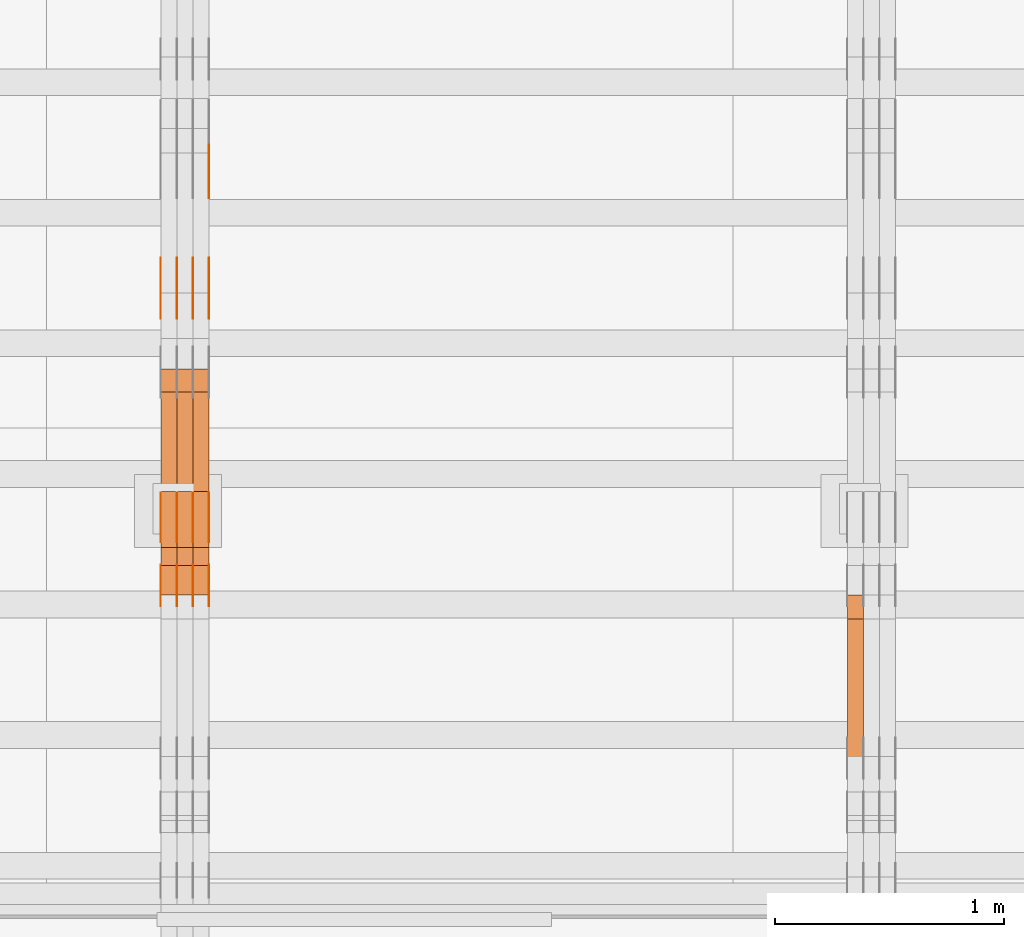
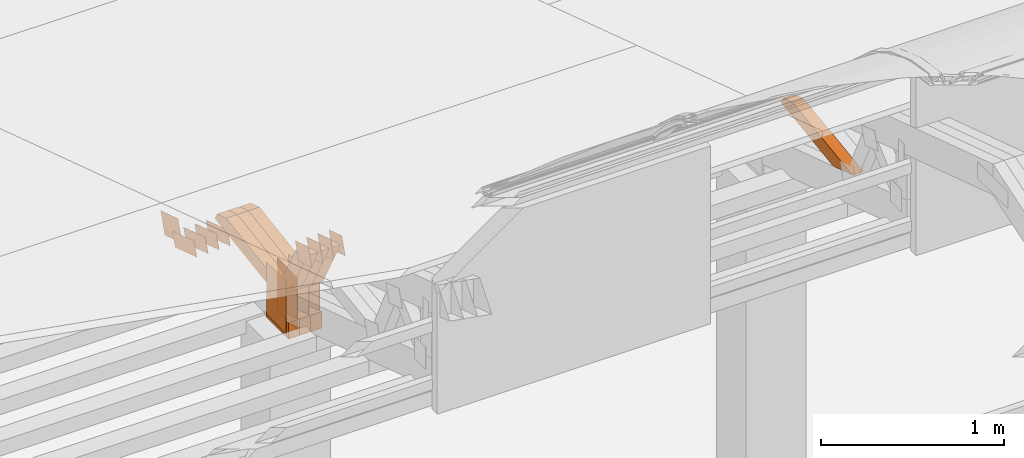
# One storey, part 291 of 385: 29 proxies.
"""IFC2X3 building model written with IfcOpenShell, lengths in millimetres."""

from ifc_helpers import new_model, entity, si_unit, converted_unit, derived_unit, direction, frame, origin, origin_2d_with_axis, place, context, subcontext, project, spatial, polyline, rectangle, outline, extrude, source, transform, mapped, material, type_object, type_shapes, element, save


model = new_model("IFC2X3")

# Units and contexts
model_context = context("Model", 3, precision=0.01, world=origin(), true_north=direction((6.12303176911189e-17, 1.0)))
body_context = subcontext(model_context, "Body", "Model", "MODEL_VIEW")
ifc_project = project(units=[si_unit("LENGTHUNIT", "METRE", prefix="MILLI"), si_unit("AREAUNIT", "SQUARE_METRE"), si_unit("VOLUMEUNIT", "CUBIC_METRE"), converted_unit("PLANEANGLEUNIT", "DEGREE", entity("IfcRatioMeasure", 0.0174532925199433), si_unit("PLANEANGLEUNIT", "RADIAN"), dimensions=[0, 0, 0, 0, 0, 0, 0]), si_unit("MASSUNIT", "GRAM", prefix="KILO"), derived_unit("MASSDENSITYUNIT", [(si_unit("MASSUNIT", "GRAM", prefix="KILO"), 1), (si_unit("LENGTHUNIT", "METRE"), -3)]), si_unit("TIMEUNIT", "SECOND"), si_unit("FREQUENCYUNIT", "HERTZ"), si_unit("THERMODYNAMICTEMPERATUREUNIT", "DEGREE_CELSIUS"), derived_unit("THERMALTRANSMITTANCEUNIT", [(si_unit("MASSUNIT", "GRAM", prefix="KILO"), 1), (si_unit("THERMODYNAMICTEMPERATUREUNIT", "KELVIN"), -1), (si_unit("TIMEUNIT", "SECOND"), -3)]), derived_unit("VOLUMETRICFLOWRATEUNIT", [(si_unit("LENGTHUNIT", "METRE"), 3), (si_unit("TIMEUNIT", "SECOND"), -1)]), si_unit("ELECTRICCURRENTUNIT", "AMPERE"), si_unit("ELECTRICVOLTAGEUNIT", "VOLT"), si_unit("POWERUNIT", "WATT"), si_unit("FORCEUNIT", "NEWTON", prefix="KILO"), si_unit("ILLUMINANCEUNIT", "LUX"), si_unit("LUMINOUSFLUXUNIT", "LUMEN"), si_unit("LUMINOUSINTENSITYUNIT", "CANDELA"), derived_unit("USERDEFINED", [(si_unit("MASSUNIT", "GRAM", prefix="KILO"), -1), (si_unit("LENGTHUNIT", "METRE"), -2), (si_unit("TIMEUNIT", "SECOND"), 3), (si_unit("LUMINOUSFLUXUNIT", "LUMEN"), 1)]), derived_unit("LINEARVELOCITYUNIT", [(si_unit("LENGTHUNIT", "METRE"), 1), (si_unit("TIMEUNIT", "SECOND"), -1)]), si_unit("PRESSUREUNIT", "PASCAL"), derived_unit("USERDEFINED", [(si_unit("LENGTHUNIT", "METRE"), -2), (si_unit("MASSUNIT", "GRAM", prefix="KILO"), 1), (si_unit("TIMEUNIT", "SECOND"), -2)])], contexts=[model_context])

# Site, building, storey
site_placement = place(None, origin())
site = spatial("IfcSite", under=ifc_project, at=site_placement, CompositionType="ELEMENT")
building_placement = place(site_placement, origin())
building = spatial("IfcBuilding", under=site, at=building_placement, CompositionType="ELEMENT")
storey_placement = place(building_placement, origin())
storey = spatial("IfcBuildingStorey", under=building, at=storey_placement, Name="Default", CompositionType="ELEMENT", Elevation=0.0)

# Proxies
ifc_material_1 = material(Name="IfcSurfaceStyle #464898")
building_element_proxy_type_1 = type_object("IfcBuildingElementProxyType", Name="T1-W8 464896", PredefinedType="NOTDEFINED", material=ifc_material_1)
shared_shape_1 = source(origin(), body_context, "Body", "SweptSolid", [
    extrude(outline(polyline([(-476.725263324644, -47.5001051695965), (180.672765845439, -47.5001051695965), (279.11020091716, -1.03605560390907e-06), (296.793624402619, 47.5001056876243), (-279.851327840575, 47.5001056876243), (-476.725263324644, -47.5001051695965)])), frame((296.793624402619, 47.5001056876243, 0.0), z_axis=(0.0, 0.0, 1.0), x_axis=(-1.0, 0.0, 0.0)), (0.0, 0.0, 1.0), 70.0),
])
type_shapes(building_element_proxy_type_1, [shared_shape_1])
proxy_1_placement = place(building_placement, frame((39245.0, 17036.40625, 3432.97192382813), z_axis=(-1.0, 0.0, 0.0), x_axis=(0.0, -0.990844046556832, -0.135011389900564)))
element("IfcBuildingElementProxy", 1, at=proxy_1_placement, inside=storey, type_object=building_element_proxy_type_1, material=ifc_material_1, Name="T1-W8", context=body_context, shape_type="MappedRepresentation", body=[
    mapped(shared_shape_1, transform((0.0, 0.0, 0.0), scale=1.0)),
])
ifc_material_2 = material(Name="IfcSurfaceStyle #445718")
building_element_proxy_type_2 = type_object("IfcBuildingElementProxyType", PredefinedType="NOTDEFINED", material=ifc_material_2)
shared_shape_2 = source(origin(), body_context, "Body", "SweptSolid", [
    extrude(outline(polyline([(-125.00031378339, -47.9999612158856), (125.000225258022, -47.9999612158856), (124.999811678525, 47.9999612158856), (-124.999723153156, 47.9999612158856), (-125.00031378339, -47.9999612158856)])), frame((125.000225258022, 48.0000091013474, 0.0), z_axis=(0.0, 0.0, 1.0), x_axis=(-1.0, 0.0, 0.0)), (0.0, 0.0, 1.0), 1.3),
])
type_shapes(building_element_proxy_type_2, [shared_shape_2])
proxy_2_placement = place(building_placement, frame((36386.3, 18456.8597683375, 2657.46691321253), z_axis=(-1.0, 0.0, 0.0), x_axis=(0.0, -0.951056516295124, 0.309016994375039)))
element("IfcBuildingElementProxy", 2, at=proxy_2_placement, inside=storey, type_object=building_element_proxy_type_2, material=ifc_material_2, context=body_context, shape_type="MappedRepresentation", body=[
    mapped(shared_shape_2, transform((0.0, 0.0, 0.0), scale=1.0)),
])
ifc_material_3 = material(Name="IfcSurfaceStyle #445661")
building_element_proxy_type_3 = type_object("IfcBuildingElementProxyType", PredefinedType="NOTDEFINED", material=ifc_material_3)
shared_shape_3 = source(origin(), body_context, "Body", "SweptSolid", [
    extrude(outline(polyline([(-125.00031378339, -47.9999612158856), (125.000225258022, -47.9999612158856), (124.999811678525, 47.9999612158856), (-124.999723153156, 47.9999612158856), (-125.00031378339, -47.9999612158856)])), frame((125.000225258022, 48.0000091013474, 0.0), z_axis=(0.0, 0.0, 1.0), x_axis=(-1.0, 0.0, 0.0)), (0.0, 0.0, 1.0), 1.3),
])
type_shapes(building_element_proxy_type_3, [shared_shape_3])
proxy_3_placement = place(building_placement, frame((36315.0, 18456.8597683375, 2657.46691321253), z_axis=(-1.0, 0.0, 0.0), x_axis=(0.0, -0.951056516295124, 0.309016994375039)))
element("IfcBuildingElementProxy", 3, at=proxy_3_placement, inside=storey, type_object=building_element_proxy_type_3, material=ifc_material_3, context=body_context, shape_type="MappedRepresentation", body=[
    mapped(shared_shape_3, transform((0.0, 0.0, 0.0), scale=1.0)),
])
ifc_material_4 = material(Name="IfcSurfaceStyle #445604")
building_element_proxy_type_4 = type_object("IfcBuildingElementProxyType", PredefinedType="NOTDEFINED", material=ifc_material_4)
shared_shape_4 = source(origin(), body_context, "Body", "SweptSolid", [
    extrude(outline(polyline([(-125.00031378339, -47.9999612158856), (125.000225258022, -47.9999612158856), (124.999811678525, 47.9999612158856), (-124.999723153156, 47.9999612158856), (-125.00031378339, -47.9999612158856)])), frame((125.000225258022, 48.0000091013474, 0.0), z_axis=(0.0, 0.0, 1.0), x_axis=(-1.0, 0.0, 0.0)), (0.0, 0.0, 1.0), 1.3),
])
type_shapes(building_element_proxy_type_4, [shared_shape_4])
proxy_4_placement = place(building_placement, frame((36316.3, 18456.8597683375, 2657.46691321253), z_axis=(-1.0, 0.0, 0.0), x_axis=(0.0, -0.951056516295124, 0.309016994375039)))
element("IfcBuildingElementProxy", 4, at=proxy_4_placement, inside=storey, type_object=building_element_proxy_type_4, material=ifc_material_4, context=body_context, shape_type="MappedRepresentation", body=[
    mapped(shared_shape_4, transform((0.0, 0.0, 0.0), scale=1.0)),
])
ifc_material_5 = material(Name="IfcSurfaceStyle #445547")
building_element_proxy_type_5 = type_object("IfcBuildingElementProxyType", PredefinedType="NOTDEFINED", material=ifc_material_5)
shared_shape_5 = source(origin(), body_context, "Body", "SweptSolid", [
    extrude(outline(polyline([(-125.00031378339, -47.9999612158856), (125.000225258022, -47.9999612158856), (124.999811678525, 47.9999612158856), (-124.999723153156, 47.9999612158856), (-125.00031378339, -47.9999612158856)])), frame((125.000225258022, 48.0000091013474, 0.0), z_axis=(0.0, 0.0, 1.0), x_axis=(-1.0, 0.0, 0.0)), (0.0, 0.0, 1.0), 1.29999999999998),
])
type_shapes(building_element_proxy_type_5, [shared_shape_5])
proxy_5_placement = place(building_placement, frame((36245.0, 18456.8597683375, 2657.46691321253), z_axis=(-1.0, 0.0, 0.0), x_axis=(0.0, -0.951056516295124, 0.309016994375039)))
element("IfcBuildingElementProxy", 5, at=proxy_5_placement, inside=storey, type_object=building_element_proxy_type_5, material=ifc_material_5, context=body_context, shape_type="MappedRepresentation", body=[
    mapped(shared_shape_5, transform((0.0, 0.0, 0.0), scale=1.0)),
])
ifc_material_6 = material(Name="IfcSurfaceStyle #445490")
building_element_proxy_type_6 = type_object("IfcBuildingElementProxyType", PredefinedType="NOTDEFINED", material=ifc_material_6)
shared_shape_6 = source(origin(), body_context, "Body", "SweptSolid", [
    extrude(outline(polyline([(-125.00031378339, -47.9999612158856), (125.000225258022, -47.9999612158856), (124.999811678525, 47.9999612158856), (-124.999723153156, 47.9999612158856), (-125.00031378339, -47.9999612158856)])), frame((125.000225258022, 48.0000091013474, 0.0), z_axis=(0.0, 0.0, 1.0), x_axis=(-1.0, 0.0, 0.0)), (0.0, 0.0, 1.0), 1.29999999999998),
])
type_shapes(building_element_proxy_type_6, [shared_shape_6])
proxy_6_placement = place(building_placement, frame((36246.3, 18456.8597683375, 2657.46691321253), z_axis=(-1.0, 0.0, 0.0), x_axis=(0.0, -0.951056516295124, 0.309016994375039)))
element("IfcBuildingElementProxy", 6, at=proxy_6_placement, inside=storey, type_object=building_element_proxy_type_6, material=ifc_material_6, context=body_context, shape_type="MappedRepresentation", body=[
    mapped(shared_shape_6, transform((0.0, 0.0, 0.0), scale=1.0)),
])
ifc_material_7 = material(Name="IfcSurfaceStyle #445433")
building_element_proxy_type_7 = type_object("IfcBuildingElementProxyType", PredefinedType="NOTDEFINED", material=ifc_material_7)
shared_shape_7 = source(origin(), body_context, "Body", "SweptSolid", [
    extrude(outline(polyline([(-125.00031378339, -47.9999612158856), (125.000225258022, -47.9999612158856), (124.999811678525, 47.9999612158856), (-124.999723153156, 47.9999612158856), (-125.00031378339, -47.9999612158856)])), frame((125.000225258022, 48.0000091013474, 0.0), z_axis=(0.0, 0.0, 1.0), x_axis=(-1.0, 0.0, 0.0)), (0.0, 0.0, 1.0), 1.29999999999998),
])
type_shapes(building_element_proxy_type_7, [shared_shape_7])
proxy_7_placement = place(building_placement, frame((36175.0, 18456.8597683375, 2657.46691321253), z_axis=(-1.0, 0.0, 0.0), x_axis=(0.0, -0.951056516295124, 0.309016994375039)))
element("IfcBuildingElementProxy", 7, at=proxy_7_placement, inside=storey, type_object=building_element_proxy_type_7, material=ifc_material_7, context=body_context, shape_type="MappedRepresentation", body=[
    mapped(shared_shape_7, transform((0.0, 0.0, 0.0), scale=1.0)),
])
ifc_material_8 = material(Name="IfcSurfaceStyle #444008")
building_element_proxy_type_8 = type_object("IfcBuildingElementProxyType", PredefinedType="NOTDEFINED", material=ifc_material_8)
shared_shape_8 = source(origin(), body_context, "Body", "SweptSolid", [
    extrude(outline(polyline([(-99.999796294464, -72.0000050220467), (99.9998768370438, -72.0000050220467), (100.000260677528, 72.0000050220467), (-100.000341220108, 72.0000050220467), (-99.999796294464, -72.0000050220467)])), frame((100.000260677528, 72.0000050220467, 0.0), z_axis=(0.0, 0.0, 1.0), x_axis=(-1.0, 0.0, 0.0)), (0.0, 0.0, 1.0), 1.3),
])
type_shapes(building_element_proxy_type_8, [shared_shape_8])
proxy_8_placement = place(building_placement, frame((36386.3, 18936.3876569477, 2373.90613192527), z_axis=(-1.0, 0.0, 0.0), x_axis=(0.0, -0.951056516295124, 0.309016994375039)))
element("IfcBuildingElementProxy", 8, at=proxy_8_placement, inside=storey, type_object=building_element_proxy_type_8, material=ifc_material_8, context=body_context, shape_type="MappedRepresentation", body=[
    mapped(shared_shape_8, transform((0.0, 0.0, 0.0), scale=1.0)),
])
ifc_material_9 = material(Name="IfcSurfaceStyle #443666")
building_element_proxy_type_9 = type_object("IfcBuildingElementProxyType", PredefinedType="NOTDEFINED", material=ifc_material_9)
shared_shape_9 = source(origin(), body_context, "Body", "SweptSolid", [
    extrude(rectangle(XDim=350.0, YDim=215.999999999984, at=origin_2d_with_axis()), frame((175.0, 108.0, 0.0), z_axis=(0.0, 0.0, 1.0), x_axis=(-1.0, 0.0, 0.0)), (0.0, 0.0, 1.0), 1.29999999999999),
])
type_shapes(building_element_proxy_type_9, [shared_shape_9])
proxy_9_placement = place(building_placement, frame((36386.3, 17459.2939453125, 3165.36425781251), z_axis=(-1.0, 0.0, 0.0), x_axis=(0.0, 0.0, -1.0)))
element("IfcBuildingElementProxy", 9, at=proxy_9_placement, inside=storey, type_object=building_element_proxy_type_9, material=ifc_material_9, context=body_context, shape_type="MappedRepresentation", body=[
    mapped(shared_shape_9, transform((0.0, 0.0, 0.0), scale=1.0)),
])
ifc_material_10 = material(Name="IfcSurfaceStyle #443609")
building_element_proxy_type_10 = type_object("IfcBuildingElementProxyType", PredefinedType="NOTDEFINED", material=ifc_material_10)
shared_shape_10 = source(origin(), body_context, "Body", "SweptSolid", [
    extrude(rectangle(XDim=350.0, YDim=215.999999999984, at=origin_2d_with_axis()), frame((175.0, 108.0, 0.0), z_axis=(0.0, 0.0, 1.0), x_axis=(-1.0, 0.0, 0.0)), (0.0, 0.0, 1.0), 1.29999999999999),
])
type_shapes(building_element_proxy_type_10, [shared_shape_10])
proxy_10_placement = place(building_placement, frame((36315.0, 17459.2939453125, 3165.36425781251), z_axis=(-1.0, 0.0, 0.0), x_axis=(0.0, 0.0, -1.0)))
element("IfcBuildingElementProxy", 10, at=proxy_10_placement, inside=storey, type_object=building_element_proxy_type_10, material=ifc_material_10, context=body_context, shape_type="MappedRepresentation", body=[
    mapped(shared_shape_10, transform((0.0, 0.0, 0.0), scale=1.0)),
])
ifc_material_11 = material(Name="IfcSurfaceStyle #443552")
building_element_proxy_type_11 = type_object("IfcBuildingElementProxyType", PredefinedType="NOTDEFINED", material=ifc_material_11)
shared_shape_11 = source(origin(), body_context, "Body", "SweptSolid", [
    extrude(rectangle(XDim=350.0, YDim=215.999999999984, at=origin_2d_with_axis()), frame((175.0, 108.0, 0.0), z_axis=(0.0, 0.0, 1.0), x_axis=(-1.0, 0.0, 0.0)), (0.0, 0.0, 1.0), 1.29999999999999),
])
type_shapes(building_element_proxy_type_11, [shared_shape_11])
proxy_11_placement = place(building_placement, frame((36316.3, 17459.2939453125, 3165.36425781251), z_axis=(-1.0, 0.0, 0.0), x_axis=(0.0, 0.0, -1.0)))
element("IfcBuildingElementProxy", 11, at=proxy_11_placement, inside=storey, type_object=building_element_proxy_type_11, material=ifc_material_11, context=body_context, shape_type="MappedRepresentation", body=[
    mapped(shared_shape_11, transform((0.0, 0.0, 0.0), scale=1.0)),
])
ifc_material_12 = material(Name="IfcSurfaceStyle #443495")
building_element_proxy_type_12 = type_object("IfcBuildingElementProxyType", PredefinedType="NOTDEFINED", material=ifc_material_12)
shared_shape_12 = source(origin(), body_context, "Body", "SweptSolid", [
    extrude(rectangle(XDim=350.0, YDim=215.999999999984, at=origin_2d_with_axis()), frame((175.0, 108.0, 0.0), z_axis=(0.0, 0.0, 1.0), x_axis=(-1.0, 0.0, 0.0)), (0.0, 0.0, 1.0), 1.29999999999998),
])
type_shapes(building_element_proxy_type_12, [shared_shape_12])
proxy_12_placement = place(building_placement, frame((36245.0, 17459.2939453125, 3165.36425781251), z_axis=(-1.0, 0.0, 0.0), x_axis=(0.0, 0.0, -1.0)))
element("IfcBuildingElementProxy", 12, at=proxy_12_placement, inside=storey, type_object=building_element_proxy_type_12, material=ifc_material_12, context=body_context, shape_type="MappedRepresentation", body=[
    mapped(shared_shape_12, transform((0.0, 0.0, 0.0), scale=1.0)),
])
ifc_material_13 = material(Name="IfcSurfaceStyle #443438")
building_element_proxy_type_13 = type_object("IfcBuildingElementProxyType", PredefinedType="NOTDEFINED", material=ifc_material_13)
shared_shape_13 = source(origin(), body_context, "Body", "SweptSolid", [
    extrude(rectangle(XDim=350.0, YDim=215.999999999984, at=origin_2d_with_axis()), frame((175.0, 108.0, 0.0), z_axis=(0.0, 0.0, 1.0), x_axis=(-1.0, 0.0, 0.0)), (0.0, 0.0, 1.0), 1.29999999999998),
])
type_shapes(building_element_proxy_type_13, [shared_shape_13])
proxy_13_placement = place(building_placement, frame((36246.3, 17459.2939453125, 3165.36425781251), z_axis=(-1.0, 0.0, 0.0), x_axis=(0.0, 0.0, -1.0)))
element("IfcBuildingElementProxy", 13, at=proxy_13_placement, inside=storey, type_object=building_element_proxy_type_13, material=ifc_material_13, context=body_context, shape_type="MappedRepresentation", body=[
    mapped(shared_shape_13, transform((0.0, 0.0, 0.0), scale=1.0)),
])
ifc_material_14 = material(Name="IfcSurfaceStyle #443381")
building_element_proxy_type_14 = type_object("IfcBuildingElementProxyType", PredefinedType="NOTDEFINED", material=ifc_material_14)
shared_shape_14 = source(origin(), body_context, "Body", "SweptSolid", [
    extrude(rectangle(XDim=350.0, YDim=215.999999999984, at=origin_2d_with_axis()), frame((175.0, 108.0, 0.0), z_axis=(0.0, 0.0, 1.0), x_axis=(-1.0, 0.0, 0.0)), (0.0, 0.0, 1.0), 1.29999999999998),
])
type_shapes(building_element_proxy_type_14, [shared_shape_14])
proxy_14_placement = place(building_placement, frame((36175.0, 17459.2939453125, 3165.36425781251), z_axis=(-1.0, 0.0, 0.0), x_axis=(0.0, 0.0, -1.0)))
element("IfcBuildingElementProxy", 14, at=proxy_14_placement, inside=storey, type_object=building_element_proxy_type_14, material=ifc_material_14, context=body_context, shape_type="MappedRepresentation", body=[
    mapped(shared_shape_14, transform((0.0, 0.0, 0.0), scale=1.0)),
])
ifc_material_15 = material(Name="IfcSurfaceStyle #440246")
building_element_proxy_type_15 = type_object("IfcBuildingElementProxyType", PredefinedType="NOTDEFINED", material=ifc_material_15)
shared_shape_15 = source(origin(), body_context, "Body", "SweptSolid", [
    extrude(outline(polyline([(-74.9998605591058, -59.9999264677524), (74.999875428623, -59.9999264677524), (74.9998605591068, 59.9999264677524), (-74.9998754286239, 59.9999264677524), (-74.9998605591058, -59.9999264677524)])), frame((75.0002460484325, 60.0000016373508, 0.0), z_axis=(0.0, 0.0, 1.0), x_axis=(-1.0, 0.0, 0.0)), (0.0, 0.0, 1.0), 1.3),
])
type_shapes(building_element_proxy_type_15, [shared_shape_15])
proxy_15_placement = place(building_placement, frame((36386.3, 17107.0599369346, 3383.82825001787), z_axis=(-1.0, 0.0, 0.0), x_axis=(0.0, -0.951056516295154, 0.309016994374948)))
element("IfcBuildingElementProxy", 15, at=proxy_15_placement, inside=storey, type_object=building_element_proxy_type_15, material=ifc_material_15, context=body_context, shape_type="MappedRepresentation", body=[
    mapped(shared_shape_15, transform((0.0, 0.0, 0.0), scale=1.0)),
])
ifc_material_16 = material(Name="IfcSurfaceStyle #440189")
building_element_proxy_type_16 = type_object("IfcBuildingElementProxyType", PredefinedType="NOTDEFINED", material=ifc_material_16)
shared_shape_16 = source(origin(), body_context, "Body", "SweptSolid", [
    extrude(outline(polyline([(-74.9998605591058, -59.9999264677524), (74.999875428623, -59.9999264677524), (74.9998605591068, 59.9999264677524), (-74.9998754286239, 59.9999264677524), (-74.9998605591058, -59.9999264677524)])), frame((75.0002460484325, 60.0000016373508, 0.0), z_axis=(0.0, 0.0, 1.0), x_axis=(-1.0, 0.0, 0.0)), (0.0, 0.0, 1.0), 1.3),
])
type_shapes(building_element_proxy_type_16, [shared_shape_16])
proxy_16_placement = place(building_placement, frame((36315.0, 17107.0599369346, 3383.82825001787), z_axis=(-1.0, 0.0, 0.0), x_axis=(0.0, -0.951056516295154, 0.309016994374948)))
element("IfcBuildingElementProxy", 16, at=proxy_16_placement, inside=storey, type_object=building_element_proxy_type_16, material=ifc_material_16, context=body_context, shape_type="MappedRepresentation", body=[
    mapped(shared_shape_16, transform((0.0, 0.0, 0.0), scale=1.0)),
])
ifc_material_17 = material(Name="IfcSurfaceStyle #440132")
building_element_proxy_type_17 = type_object("IfcBuildingElementProxyType", PredefinedType="NOTDEFINED", material=ifc_material_17)
shared_shape_17 = source(origin(), body_context, "Body", "SweptSolid", [
    extrude(outline(polyline([(-74.9998605591058, -59.9999264677524), (74.999875428623, -59.9999264677524), (74.9998605591068, 59.9999264677524), (-74.9998754286239, 59.9999264677524), (-74.9998605591058, -59.9999264677524)])), frame((75.0002460484325, 60.0000016373508, 0.0), z_axis=(0.0, 0.0, 1.0), x_axis=(-1.0, 0.0, 0.0)), (0.0, 0.0, 1.0), 1.3),
])
type_shapes(building_element_proxy_type_17, [shared_shape_17])
proxy_17_placement = place(building_placement, frame((36316.3, 17107.0599369346, 3383.82825001787), z_axis=(-1.0, 0.0, 0.0), x_axis=(0.0, -0.951056516295154, 0.309016994374948)))
element("IfcBuildingElementProxy", 17, at=proxy_17_placement, inside=storey, type_object=building_element_proxy_type_17, material=ifc_material_17, context=body_context, shape_type="MappedRepresentation", body=[
    mapped(shared_shape_17, transform((0.0, 0.0, 0.0), scale=1.0)),
])
ifc_material_18 = material(Name="IfcSurfaceStyle #440075")
building_element_proxy_type_18 = type_object("IfcBuildingElementProxyType", PredefinedType="NOTDEFINED", material=ifc_material_18)
shared_shape_18 = source(origin(), body_context, "Body", "SweptSolid", [
    extrude(outline(polyline([(-74.9998605591058, -59.9999264677524), (74.999875428623, -59.9999264677524), (74.9998605591068, 59.9999264677524), (-74.9998754286239, 59.9999264677524), (-74.9998605591058, -59.9999264677524)])), frame((75.0002460484325, 60.0000016373508, 0.0), z_axis=(0.0, 0.0, 1.0), x_axis=(-1.0, 0.0, 0.0)), (0.0, 0.0, 1.0), 1.29999999999999),
])
type_shapes(building_element_proxy_type_18, [shared_shape_18])
proxy_18_placement = place(building_placement, frame((36245.0, 17107.0599369346, 3383.82825001787), z_axis=(-1.0, 0.0, 0.0), x_axis=(0.0, -0.951056516295154, 0.309016994374948)))
element("IfcBuildingElementProxy", 18, at=proxy_18_placement, inside=storey, type_object=building_element_proxy_type_18, material=ifc_material_18, context=body_context, shape_type="MappedRepresentation", body=[
    mapped(shared_shape_18, transform((0.0, 0.0, 0.0), scale=1.0)),
])
ifc_material_19 = material(Name="IfcSurfaceStyle #440018")
building_element_proxy_type_19 = type_object("IfcBuildingElementProxyType", PredefinedType="NOTDEFINED", material=ifc_material_19)
shared_shape_19 = source(origin(), body_context, "Body", "SweptSolid", [
    extrude(outline(polyline([(-74.9998605591058, -59.9999264677524), (74.999875428623, -59.9999264677524), (74.9998605591068, 59.9999264677524), (-74.9998754286239, 59.9999264677524), (-74.9998605591058, -59.9999264677524)])), frame((75.0002460484325, 60.0000016373508, 0.0), z_axis=(0.0, 0.0, 1.0), x_axis=(-1.0, 0.0, 0.0)), (0.0, 0.0, 1.0), 1.29999999999999),
])
type_shapes(building_element_proxy_type_19, [shared_shape_19])
proxy_19_placement = place(building_placement, frame((36246.3, 17107.0599369346, 3383.82825001787), z_axis=(-1.0, 0.0, 0.0), x_axis=(0.0, -0.951056516295154, 0.309016994374948)))
element("IfcBuildingElementProxy", 19, at=proxy_19_placement, inside=storey, type_object=building_element_proxy_type_19, material=ifc_material_19, context=body_context, shape_type="MappedRepresentation", body=[
    mapped(shared_shape_19, transform((0.0, 0.0, 0.0), scale=1.0)),
])
ifc_material_20 = material(Name="IfcSurfaceStyle #439961")
building_element_proxy_type_20 = type_object("IfcBuildingElementProxyType", PredefinedType="NOTDEFINED", material=ifc_material_20)
shared_shape_20 = source(origin(), body_context, "Body", "SweptSolid", [
    extrude(outline(polyline([(-74.9998605591058, -59.9999264677524), (74.999875428623, -59.9999264677524), (74.9998605591068, 59.9999264677524), (-74.9998754286239, 59.9999264677524), (-74.9998605591058, -59.9999264677524)])), frame((75.0002460484325, 60.0000016373508, 0.0), z_axis=(0.0, 0.0, 1.0), x_axis=(-1.0, 0.0, 0.0)), (0.0, 0.0, 1.0), 1.29999999999999),
])
type_shapes(building_element_proxy_type_20, [shared_shape_20])
proxy_20_placement = place(building_placement, frame((36175.0, 17107.0599369346, 3383.82825001787), z_axis=(-1.0, 0.0, 0.0), x_axis=(0.0, -0.951056516295154, 0.309016994374948)))
element("IfcBuildingElementProxy", 20, at=proxy_20_placement, inside=storey, type_object=building_element_proxy_type_20, material=ifc_material_20, context=body_context, shape_type="MappedRepresentation", body=[
    mapped(shared_shape_20, transform((0.0, 0.0, 0.0), scale=1.0)),
])
ifc_material_21 = material(Name="IfcSurfaceStyle #431957")
building_element_proxy_type_21 = type_object("IfcBuildingElementProxyType", Name="T1-E1 431955", PredefinedType="NOTDEFINED", material=ifc_material_21)
shared_shape_21 = source(origin(), body_context, "Body", "SweptSolid", [
    extrude(outline(polyline([(4.4675903320374, -122.500000000001), (35.3350219726624, -122.500000000001), (35.3350219726501, 122.500000000001), (-75.1376342773499, 122.500000000001), (4.4675903320374, -122.500000000001)])), frame((35.3350219726624, 122.50000005215, 0.0), z_axis=(0.0, 0.0, 1.0), x_axis=(-1.0, 0.0, 0.0)), (0.0, 0.0, 1.0), 70.0),
])
type_shapes(building_element_proxy_type_21, [shared_shape_21])
proxy_21_placement = place(building_placement, frame((36385.0, 17220.0, 2794.30932617186), z_axis=(-1.0, 0.0, 0.0), x_axis=(0.0, 0.0, 1.0)))
element("IfcBuildingElementProxy", 21, at=proxy_21_placement, inside=storey, type_object=building_element_proxy_type_21, material=ifc_material_21, Name="T1-E1", context=body_context, shape_type="MappedRepresentation", body=[
    mapped(shared_shape_21, transform((0.0, 0.0, 0.0), scale=1.0)),
])
ifc_material_22 = material(Name="IfcSurfaceStyle #431900")
building_element_proxy_type_22 = type_object("IfcBuildingElementProxyType", Name="T1-E1 431898", PredefinedType="NOTDEFINED", material=ifc_material_22)
shared_shape_22 = source(origin(), body_context, "Body", "SweptSolid", [
    extrude(outline(polyline([(4.4675903320374, -122.500000000001), (35.3350219726624, -122.500000000001), (35.3350219726501, 122.500000000001), (-75.1376342773499, 122.500000000001), (4.4675903320374, -122.500000000001)])), frame((35.3350219726624, 122.50000005215, 0.0), z_axis=(0.0, 0.0, 1.0), x_axis=(-1.0, 0.0, 0.0)), (0.0, 0.0, 1.0), 70.0),
])
type_shapes(building_element_proxy_type_22, [shared_shape_22])
proxy_22_placement = place(building_placement, frame((36315.0, 17220.0, 2794.30932617186), z_axis=(-1.0, 0.0, 0.0), x_axis=(0.0, 0.0, 1.0)))
element("IfcBuildingElementProxy", 22, at=proxy_22_placement, inside=storey, type_object=building_element_proxy_type_22, material=ifc_material_22, Name="T1-E1", context=body_context, shape_type="MappedRepresentation", body=[
    mapped(shared_shape_22, transform((0.0, 0.0, 0.0), scale=1.0)),
])
ifc_material_23 = material(Name="IfcSurfaceStyle #431843")
building_element_proxy_type_23 = type_object("IfcBuildingElementProxyType", Name="T1-E1 431841", PredefinedType="NOTDEFINED", material=ifc_material_23)
shared_shape_23 = source(origin(), body_context, "Body", "SweptSolid", [
    extrude(outline(polyline([(4.4675903320374, -122.500000000001), (35.3350219726624, -122.500000000001), (35.3350219726501, 122.500000000001), (-75.1376342773499, 122.500000000001), (4.4675903320374, -122.500000000001)])), frame((35.3350219726624, 122.50000005215, 0.0), z_axis=(0.0, 0.0, 1.0), x_axis=(-1.0, 0.0, 0.0)), (0.0, 0.0, 1.0), 70.0),
])
type_shapes(building_element_proxy_type_23, [shared_shape_23])
proxy_23_placement = place(building_placement, frame((36245.0, 17220.0, 2794.30932617186), z_axis=(-1.0, 0.0, 0.0), x_axis=(0.0, 0.0, 1.0)))
element("IfcBuildingElementProxy", 23, at=proxy_23_placement, inside=storey, type_object=building_element_proxy_type_23, material=ifc_material_23, Name="T1-E1", context=body_context, shape_type="MappedRepresentation", body=[
    mapped(shared_shape_23, transform((0.0, 0.0, 0.0), scale=1.0)),
])
ifc_material_24 = material(Name="IfcSurfaceStyle #430202")
building_element_proxy_type_24 = type_object("IfcBuildingElementProxyType", Name="T1-W39 430200", PredefinedType="NOTDEFINED", material=ifc_material_24)
shared_shape_24 = source(origin(), body_context, "Body", "SweptSolid", [
    extrude(outline(polyline([(-191.519946663886, -47.499928106579), (188.32936223763, -47.499928106579), (171.597440144109, 0.000249483340993841), (122.102882529753, 47.4998033649085), (-290.509738247605, 47.4998033649085), (-191.519946663886, -47.499928106579)])), frame((188.329593252001, 47.499957247623, 0.0), z_axis=(0.0, 0.0, 1.0), x_axis=(-1.0, 0.0, 0.0)), (0.0, 0.0, 1.0), 70.0),
])
type_shapes(building_element_proxy_type_24, [shared_shape_24])
proxy_24_placement = place(building_placement, frame((36385.0, 17238.5876916597, 3055.56121424762), z_axis=(-1.0, 0.0, 0.0), x_axis=(0.0, -0.472216932390777, 0.881482370080902)))
element("IfcBuildingElementProxy", 24, at=proxy_24_placement, inside=storey, type_object=building_element_proxy_type_24, material=ifc_material_24, Name="T1-W39", context=body_context, shape_type="MappedRepresentation", body=[
    mapped(shared_shape_24, transform((0.0, 0.0, 0.0), scale=1.0)),
])
ifc_material_25 = material(Name="IfcSurfaceStyle #430136")
building_element_proxy_type_25 = type_object("IfcBuildingElementProxyType", Name="T1-W39 430134", PredefinedType="NOTDEFINED", material=ifc_material_25)
shared_shape_25 = source(origin(), body_context, "Body", "SweptSolid", [
    extrude(outline(polyline([(-191.519946663886, -47.499928106579), (188.32936223763, -47.499928106579), (171.597440144109, 0.000249483340993841), (122.102882529753, 47.4998033649085), (-290.509738247605, 47.4998033649085), (-191.519946663886, -47.499928106579)])), frame((188.329593252001, 47.499957247623, 0.0), z_axis=(0.0, 0.0, 1.0), x_axis=(-1.0, 0.0, 0.0)), (0.0, 0.0, 1.0), 70.0),
])
type_shapes(building_element_proxy_type_25, [shared_shape_25])
proxy_25_placement = place(building_placement, frame((36315.0, 17238.5876916597, 3055.56121424762), z_axis=(-1.0, 0.0, 0.0), x_axis=(0.0, -0.472216932390777, 0.881482370080902)))
element("IfcBuildingElementProxy", 25, at=proxy_25_placement, inside=storey, type_object=building_element_proxy_type_25, material=ifc_material_25, Name="T1-W39", context=body_context, shape_type="MappedRepresentation", body=[
    mapped(shared_shape_25, transform((0.0, 0.0, 0.0), scale=1.0)),
])
ifc_material_26 = material(Name="IfcSurfaceStyle #430070")
building_element_proxy_type_26 = type_object("IfcBuildingElementProxyType", Name="T1-W39 430068", PredefinedType="NOTDEFINED", material=ifc_material_26)
shared_shape_26 = source(origin(), body_context, "Body", "SweptSolid", [
    extrude(outline(polyline([(-191.519946663886, -47.499928106579), (188.32936223763, -47.499928106579), (171.597440144109, 0.000249483340993841), (122.102882529753, 47.4998033649085), (-290.509738247605, 47.4998033649085), (-191.519946663886, -47.499928106579)])), frame((188.329593252001, 47.499957247623, 0.0), z_axis=(0.0, 0.0, 1.0), x_axis=(-1.0, 0.0, 0.0)), (0.0, 0.0, 1.0), 70.0),
])
type_shapes(building_element_proxy_type_26, [shared_shape_26])
proxy_26_placement = place(building_placement, frame((36245.0, 17238.5876916597, 3055.56121424762), z_axis=(-1.0, 0.0, 0.0), x_axis=(0.0, -0.472216932390777, 0.881482370080902)))
element("IfcBuildingElementProxy", 26, at=proxy_26_placement, inside=storey, type_object=building_element_proxy_type_26, material=ifc_material_26, Name="T1-W39", context=body_context, shape_type="MappedRepresentation", body=[
    mapped(shared_shape_26, transform((0.0, 0.0, 0.0), scale=1.0)),
])
ifc_material_27 = material(Name="IfcSurfaceStyle #429806")
building_element_proxy_type_27 = type_object("IfcBuildingElementProxyType", Name="T1-W10 429804", PredefinedType="NOTDEFINED", material=ifc_material_27)
shared_shape_27 = source(origin(), body_context, "Body", "SweptSolid", [
    extrude(outline(polyline([(-459.546036710757, -47.5000436364511), (174.689450869018, -47.5000436364511), (268.831081103959, 0.00011114562912502), (287.286350706789, 47.4999880636365), (-271.260845969009, 47.4999880636366), (-459.546036710757, -47.5000436364511)])), frame((287.286768781132, 47.5001637448091, 0.0), z_axis=(0.0, 0.0, 1.0), x_axis=(-1.0, 0.0, 0.0)), (0.0, 0.0, 1.0), 70.0),
])
type_shapes(building_element_proxy_type_27, [shared_shape_27])
proxy_27_placement = place(building_placement, frame((36385.0, 18025.1410649788, 3112.76453857986), z_axis=(-1.0, 0.0, 0.0), x_axis=(0.0, -0.988299196256916, -0.152527698068035)))
element("IfcBuildingElementProxy", 27, at=proxy_27_placement, inside=storey, type_object=building_element_proxy_type_27, material=ifc_material_27, Name="T1-W10", context=body_context, shape_type="MappedRepresentation", body=[
    mapped(shared_shape_27, transform((0.0, 0.0, 0.0), scale=1.0)),
])
ifc_material_28 = material(Name="IfcSurfaceStyle #429740")
building_element_proxy_type_28 = type_object("IfcBuildingElementProxyType", Name="T1-W10 429738", PredefinedType="NOTDEFINED", material=ifc_material_28)
shared_shape_28 = source(origin(), body_context, "Body", "SweptSolid", [
    extrude(outline(polyline([(-459.546036710757, -47.5000436364511), (174.689450869018, -47.5000436364511), (268.831081103959, 0.00011114562912502), (287.286350706789, 47.4999880636365), (-271.260845969009, 47.4999880636366), (-459.546036710757, -47.5000436364511)])), frame((287.286768781132, 47.5001637448091, 0.0), z_axis=(0.0, 0.0, 1.0), x_axis=(-1.0, 0.0, 0.0)), (0.0, 0.0, 1.0), 70.0),
])
type_shapes(building_element_proxy_type_28, [shared_shape_28])
proxy_28_placement = place(building_placement, frame((36315.0, 18025.1410649788, 3112.76453857986), z_axis=(-1.0, 0.0, 0.0), x_axis=(0.0, -0.988299196256916, -0.152527698068035)))
element("IfcBuildingElementProxy", 28, at=proxy_28_placement, inside=storey, type_object=building_element_proxy_type_28, material=ifc_material_28, Name="T1-W10", context=body_context, shape_type="MappedRepresentation", body=[
    mapped(shared_shape_28, transform((0.0, 0.0, 0.0), scale=1.0)),
])
ifc_material_29 = material(Name="IfcSurfaceStyle #429674")
building_element_proxy_type_29 = type_object("IfcBuildingElementProxyType", Name="T1-W10 429672", PredefinedType="NOTDEFINED", material=ifc_material_29)
shared_shape_29 = source(origin(), body_context, "Body", "SweptSolid", [
    extrude(outline(polyline([(-459.546036710757, -47.5000436364511), (174.689450869018, -47.5000436364511), (268.831081103959, 0.00011114562912502), (287.286350706789, 47.4999880636365), (-271.260845969009, 47.4999880636366), (-459.546036710757, -47.5000436364511)])), frame((287.286768781132, 47.5001637448091, 0.0), z_axis=(0.0, 0.0, 1.0), x_axis=(-1.0, 0.0, 0.0)), (0.0, 0.0, 1.0), 70.0),
])
type_shapes(building_element_proxy_type_29, [shared_shape_29])
proxy_29_placement = place(building_placement, frame((36245.0, 18025.1410649788, 3112.76453857986), z_axis=(-1.0, 0.0, 0.0), x_axis=(0.0, -0.988299196256916, -0.152527698068035)))
element("IfcBuildingElementProxy", 29, at=proxy_29_placement, inside=storey, type_object=building_element_proxy_type_29, material=ifc_material_29, Name="T1-W10", context=body_context, shape_type="MappedRepresentation", body=[
    mapped(shared_shape_29, transform((0.0, 0.0, 0.0), scale=1.0)),
])

save(model, "model.ifc")
